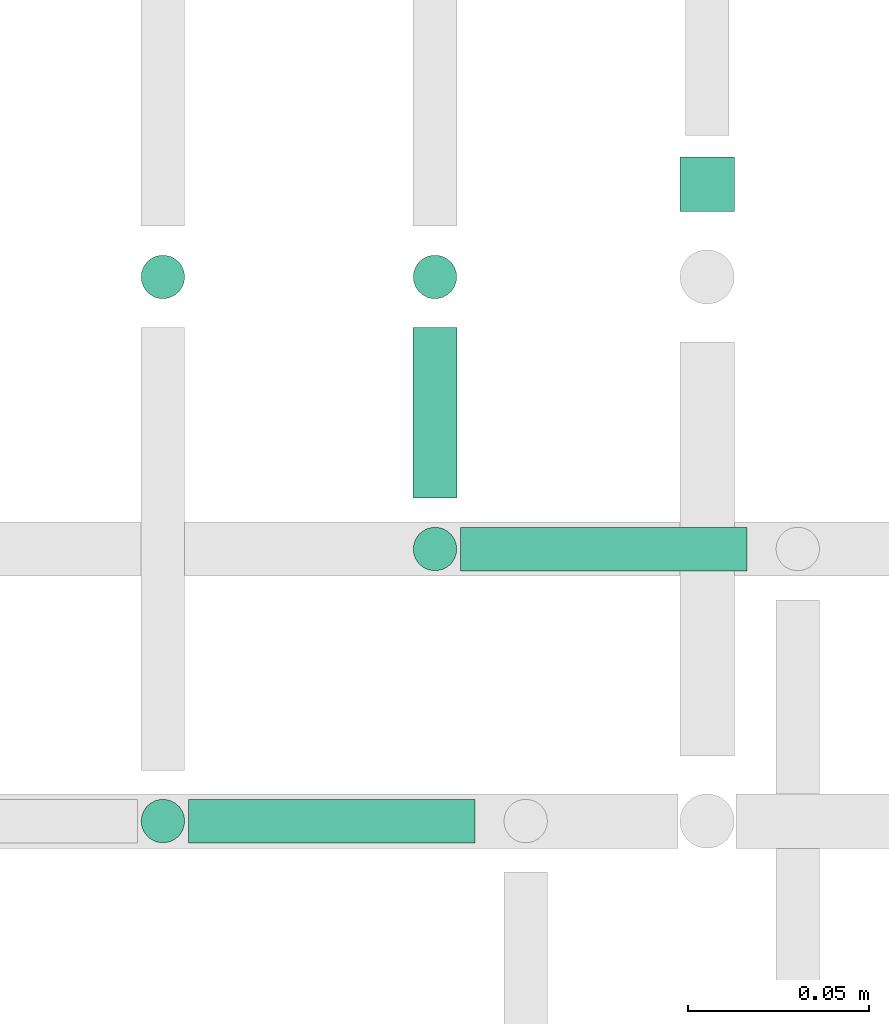
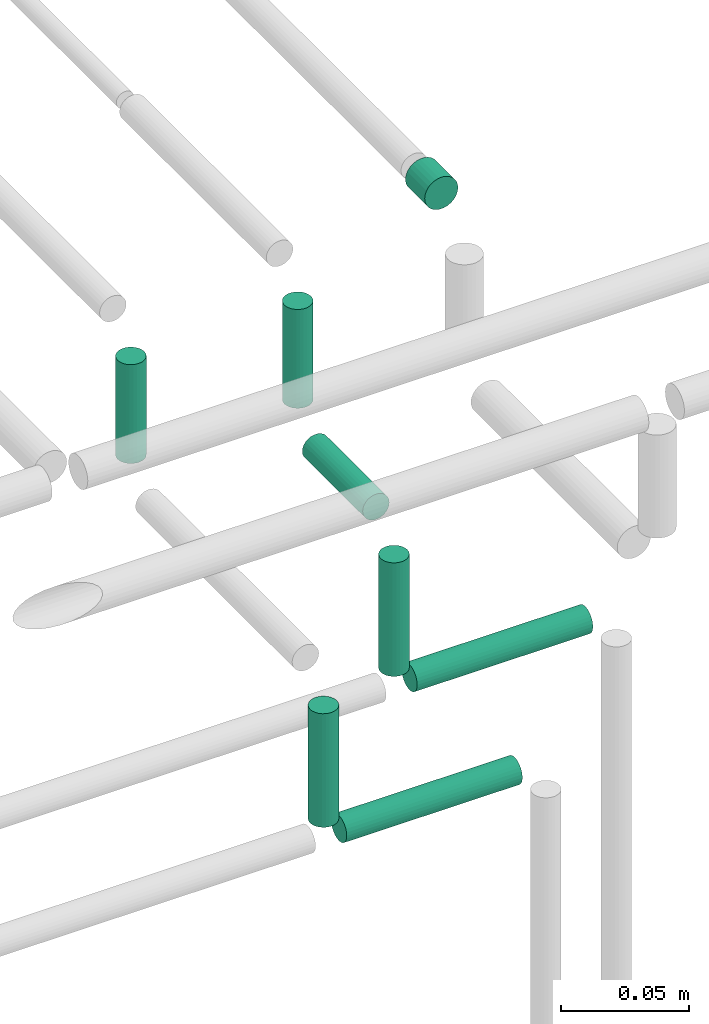
# One storey, part 322 of 331: 8 flow segments.
"""IFC2X3 building model written with IfcOpenShell, lengths in millimetres."""

import ifcopenshell
import ifcopenshell.guid

model = None  # the IFC model being written
_history = None  # IfcOwnerHistory: only IFC2X3 demands one
_inside = {}  # id of a spatial element -> (the spatial element, [elements in it])
_under = {}  # id of a project, library or spatial element -> (it, [spatial elements below it])
_declared = {}  # id of a project -> (the project, [libraries it declares])
_typed = {}  # id of a type object -> (the type object, [elements of that type])
_made_of = {}  # id of a material, layer set ... -> (it, [elements and type objects made of it])


def new_model(schema):
    """Start an empty IFC model of exactly this schema.

    Asked for "IFC4X3", IfcOpenShell would pick the latest addendum, in which some entities
    have other attributes; the version numbers below select the first issue.
    IFC2X3 requires an IfcOwnerHistory on every rooted entity: one is made here for all.
    """
    global model, _history
    if schema == "IFC4X3":
        model = ifcopenshell.file(schema_version=(4, 3, 0, 0))
    else:
        model = ifcopenshell.file(schema=schema)
    _inside.clear()
    _under.clear()
    _declared.clear()
    _typed.clear()
    _made_of.clear()
    _history = None
    if model.schema == "IFC2X3":
        org = make("IfcOrganization", Name="unknown")
        user = make(
            "IfcPersonAndOrganization",
            ThePerson=make("IfcPerson", FamilyName="unknown"),
            TheOrganization=org,
        )
        app = make(
            "IfcApplication",
            ApplicationDeveloper=org,
            Version="unknown",
            ApplicationFullName="unknown",
            ApplicationIdentifier="unknown",
        )
        _history = make(
            "IfcOwnerHistory",
            OwningUser=user,
            OwningApplication=app,
            ChangeAction="ADDED",
            CreationDate=0,
        )
    return model


def make(cls, **values):
    """One entity of the class cls with the attributes given. An attribute that is None is left unset."""
    return model.create_entity(
        cls, **{name: value for name, value in values.items() if value is not None}
    )


def entity(cls, *values):
    """Any entity or typed value of the class cls, its attributes in the order of the schema. None: left unset."""
    e = model.create_entity(cls)
    for i, value in enumerate(values):
        if value is not None:
            e[i] = value
    return e


def rooted(cls, **values):
    """An entity with a GlobalId (a new one), such as an element, a storey or a relation."""
    return make(cls, GlobalId=ifcopenshell.guid.new(), OwnerHistory=_history, **values)


def si_unit(unit_type, name, prefix=None):
    """IfcSIUnit, for example si_unit("LENGTHUNIT", "METRE", prefix="MILLI")."""
    return make("IfcSIUnit", UnitType=unit_type, Prefix=prefix, Name=name)


def converted_unit(unit_type, name, factor, base, dimensions=None, offset=None):
    """IfcConversionBasedUnit, such as the inch: factor (a typed value) times the base unit."""
    return make(
        "IfcConversionBasedUnit"
        if offset is None
        else "IfcConversionBasedUnitWithOffset",
        ConversionOffset=offset,
        Dimensions=None
        if dimensions is None
        else entity("IfcDimensionalExponents", *dimensions),
        UnitType=unit_type,
        Name=name,
        ConversionFactor=make(
            "IfcMeasureWithUnit", ValueComponent=factor, UnitComponent=base
        ),
    )


def derived_unit(unit_type, elements):
    """IfcDerivedUnit: a product of units, each with its exponent."""
    return make(
        "IfcDerivedUnit",
        Elements=[
            make("IfcDerivedUnitElement", Unit=unit, Exponent=power)
            for unit, power in elements
        ],
        UnitType=unit_type,
    )


def assignment(units):
    """IfcUnitAssignment: the units of a project."""
    return None if units is None else make("IfcUnitAssignment", Units=units)


def point(xyz):
    """IfcCartesianPoint."""
    return None if xyz is None else make("IfcCartesianPoint", Coordinates=xyz)


def direction(xyz):
    """IfcDirection."""
    return None if xyz is None else make("IfcDirection", DirectionRatios=xyz)


def frame(location, z_axis=None, x_axis=None):
    """IfcAxis2Placement3D, a coordinate frame: its origin and axes. An axis left out is left unset."""
    return make(
        "IfcAxis2Placement3D",
        Location=point(location),
        Axis=direction(z_axis),
        RefDirection=direction(x_axis),
    )


def frame_2d(location, x_axis=None):
    """IfcAxis2Placement2D, a coordinate frame in the plane: its origin and x axis."""
    return make(
        "IfcAxis2Placement2D", Location=point(location), RefDirection=direction(x_axis)
    )


def origin():
    """The frame at (0, 0, 0) with its axes left unset."""
    return frame((0.0, 0.0, 0.0))


def origin_2d_with_axis():
    """The frame at (0, 0) in the plane with the x axis (1, 0) written out."""
    return frame_2d((0.0, 0.0), x_axis=(1.0, 0.0))


def place(relative_to, where):
    """IfcLocalPlacement: puts the frame where relative to a parent placement (None: the world)."""
    return make(
        "IfcLocalPlacement", PlacementRelTo=relative_to, RelativePlacement=where
    )


def context(
    kind, dimensions, precision=None, world=None, true_north=None, identifier=None
):
    """IfcGeometricRepresentationContext, for example the 3D "Model" context."""
    return make(
        "IfcGeometricRepresentationContext",
        ContextIdentifier=identifier,
        ContextType=kind,
        CoordinateSpaceDimension=dimensions,
        Precision=precision,
        WorldCoordinateSystem=world,
        TrueNorth=true_north,
    )


def subcontext(parent, identifier, kind, view, scale=None):
    """IfcGeometricRepresentationSubContext, for example "Body" below "Model"."""
    return make(
        "IfcGeometricRepresentationSubContext",
        ContextIdentifier=identifier,
        ContextType=kind,
        ParentContext=parent,
        TargetScale=scale,
        TargetView=view,
    )


def project(units=None, contexts=None):
    """IfcProject with its units and contexts."""
    return rooted(
        "IfcProject",
        Name="project",
        RepresentationContexts=contexts,
        UnitsInContext=assignment(units),
    )


def spatial(cls, under=None, at=None, **own):
    """A site, building, storey or space (cls), placed at a placement, below another one or the project."""
    s = rooted(cls, ObjectPlacement=at, **own)
    if under is not None:
        _under.setdefault(under.id(), (under, []))[1].append(s)
    return s


def profile(cls, at=None, kind="AREA", **sizes):
    """A parametric profile (cls). Its sizes go by their IFC names, for example OverallWidth=200.0."""
    return make(cls, ProfileType=kind, Position=at, **sizes)


def circle(**sizes):
    """IfcCircleProfileDef."""
    return profile("IfcCircleProfileDef", **sizes)


def extrude(swept, where, along, depth):
    """IfcExtrudedAreaSolid: the profile swept, set in the frame where, extruded along a direction by depth."""
    return make(
        "IfcExtrudedAreaSolid",
        SweptArea=swept,
        Position=where,
        ExtrudedDirection=direction(along),
        Depth=depth,
    )


def shape(context_of_items, identifier, shape_type, items):
    """IfcShapeRepresentation: the items that make up one representation, for example the "Body"."""
    return make(
        "IfcShapeRepresentation",
        ContextOfItems=context_of_items,
        RepresentationIdentifier=identifier,
        RepresentationType=shape_type,
        Items=items,
    )


def made_of(thing, what):
    """Note that an element or type object is made of a material, layer set ...; save() writes the relation."""
    if what is not None:
        _made_of.setdefault(what.id(), (what, []))[1].append(thing)
    return thing


def type_object(cls, material=None, **own):
    """A type object (cls), such as IfcWallType, which elements share."""
    return made_of(rooted(cls, **own), material)


def element(
    cls,
    number,
    at=None,
    inside=None,
    cuts=None,
    type_object=None,
    material=None,
    context=None,
    identifier="Body",
    shape_type=None,
    held_by="IfcProductDefinitionShape",
    body=None,
    shapes=None,
    **own,
):
    """One element of the class cls, such as IfcWall. Its Tag is "e" and its number.

    at: its placement. inside: the storey or other place that contains it. cuts: it is an
    opening in that element (IfcRelVoidsElement). A single representation is given by context,
    identifier, shape_type and body (its items); several are given by shapes. held_by: the class
    of the entity that holds the representations. save() writes the other relations.
    """
    e = rooted(cls, Tag="e%d" % number, ObjectPlacement=at, **own)
    if body is not None:
        shapes = [shape(context, identifier, shape_type, body)]
    if shapes is not None:
        e.Representation = make(held_by, Representations=shapes)
    if inside is not None:
        _inside.setdefault(inside.id(), (inside, []))[1].append(e)
    if cuts is not None:
        rooted(
            "IfcRelVoidsElement", RelatingBuildingElement=cuts, RelatedOpeningElement=e
        )
    if type_object is not None:
        _typed.setdefault(type_object.id(), (type_object, []))[1].append(e)
    return made_of(e, material)


def aggregate(whole, parts):
    """IfcRelAggregates: a whole, such as a stair, and the parts it consists of."""
    return rooted("IfcRelAggregates", RelatingObject=whole, RelatedObjects=parts)


def save(model, path):
    """Write the relations noted so far, then the file.

    IfcRelAggregates (storeys below a building ...), IfcRelContainedInSpatialStructure (elements
    in a storey), IfcRelDefinesByType, IfcRelAssociatesMaterial and IfcRelDeclares: one each for
    every whole, place, type object, material and project.
    """
    for whole, parts in _under.values():
        aggregate(whole, parts)
    for where, things in _inside.values():
        rooted(
            "IfcRelContainedInSpatialStructure",
            RelatedElements=things,
            RelatingStructure=where,
        )
    for kind, things in _typed.values():
        rooted("IfcRelDefinesByType", RelatedObjects=things, RelatingType=kind)
    for what, things in _made_of.values():
        rooted("IfcRelAssociatesMaterial", RelatedObjects=things, RelatingMaterial=what)
    for by, libraries in _declared.values():
        rooted("IfcRelDeclares", RelatingContext=by, RelatedDefinitions=libraries)
    model.write(path)


model = new_model("IFC2X3")

# Units and contexts
model_context = context("Model", 3, precision=0.01, world=origin(), true_north=direction((6.12303176911189e-17, 1.0)))
body_context = subcontext(model_context, "Body", "Model", "MODEL_VIEW")
ifc_project = project(units=[si_unit("LENGTHUNIT", "METRE", prefix="MILLI"), si_unit("AREAUNIT", "SQUARE_METRE"), si_unit("VOLUMEUNIT", "CUBIC_METRE"), converted_unit("PLANEANGLEUNIT", "DEGREE", entity("IfcRatioMeasure", 0.0174532925199433), si_unit("PLANEANGLEUNIT", "RADIAN"), dimensions=[0, 0, 0, 0, 0, 0, 0]), si_unit("MASSUNIT", "GRAM", prefix="KILO"), derived_unit("MASSDENSITYUNIT", [(si_unit("MASSUNIT", "GRAM", prefix="KILO"), 1), (si_unit("LENGTHUNIT", "METRE"), -3)]), derived_unit("MOMENTOFINERTIAUNIT", [(si_unit("LENGTHUNIT", "METRE"), 4)]), si_unit("TIMEUNIT", "SECOND"), si_unit("FREQUENCYUNIT", "HERTZ"), si_unit("THERMODYNAMICTEMPERATUREUNIT", "DEGREE_CELSIUS"), derived_unit("THERMALTRANSMITTANCEUNIT", [(si_unit("MASSUNIT", "GRAM", prefix="KILO"), 1), (si_unit("THERMODYNAMICTEMPERATUREUNIT", "KELVIN"), -1), (si_unit("TIMEUNIT", "SECOND"), -3)]), derived_unit("VOLUMETRICFLOWRATEUNIT", [(si_unit("LENGTHUNIT", "METRE"), 3), (si_unit("TIMEUNIT", "SECOND"), -1)]), derived_unit("MASSFLOWRATEUNIT", [(si_unit("MASSUNIT", "GRAM", prefix="KILO"), 1), (si_unit("TIMEUNIT", "SECOND"), -1)]), derived_unit("ROTATIONALFREQUENCYUNIT", [(si_unit("TIMEUNIT", "SECOND"), -1)]), si_unit("ELECTRICCURRENTUNIT", "AMPERE"), si_unit("ELECTRICVOLTAGEUNIT", "VOLT"), si_unit("POWERUNIT", "WATT"), si_unit("FORCEUNIT", "NEWTON", prefix="KILO"), si_unit("ILLUMINANCEUNIT", "LUX"), si_unit("LUMINOUSFLUXUNIT", "LUMEN"), si_unit("LUMINOUSINTENSITYUNIT", "CANDELA"), derived_unit("USERDEFINED", [(si_unit("MASSUNIT", "GRAM", prefix="KILO"), -1), (si_unit("LENGTHUNIT", "METRE"), -2), (si_unit("TIMEUNIT", "SECOND"), 3), (si_unit("LUMINOUSFLUXUNIT", "LUMEN"), 1)]), derived_unit("LINEARVELOCITYUNIT", [(si_unit("LENGTHUNIT", "METRE"), 1), (si_unit("TIMEUNIT", "SECOND"), -1)]), si_unit("PRESSUREUNIT", "PASCAL"), derived_unit("USERDEFINED", [(si_unit("LENGTHUNIT", "METRE"), -2), (si_unit("MASSUNIT", "GRAM", prefix="KILO"), 1), (si_unit("TIMEUNIT", "SECOND"), -2)]), derived_unit("LINEARFORCEUNIT", [(si_unit("MASSUNIT", "GRAM", prefix="KILO"), 1), (si_unit("LENGTHUNIT", "METRE"), 1), (si_unit("TIMEUNIT", "SECOND"), -2), (si_unit("LENGTHUNIT", "METRE"), -1)]), derived_unit("PLANARFORCEUNIT", [(si_unit("MASSUNIT", "GRAM", prefix="KILO"), 1), (si_unit("LENGTHUNIT", "METRE"), 1), (si_unit("TIMEUNIT", "SECOND"), -2), (si_unit("LENGTHUNIT", "METRE"), -2)])], contexts=[model_context])

# Site, building, storey
site_placement = place(None, frame((0.0, -0.00077364408347762, 0.0)))
site = spatial("IfcSite", under=ifc_project, at=site_placement, CompositionType="ELEMENT")
building_placement = place(site_placement, origin())
building = spatial("IfcBuilding", under=site, at=building_placement, CompositionType="ELEMENT")
storey_placement = place(building_placement, origin())
storey = spatial("IfcBuildingStorey", under=building, at=storey_placement, CompositionType="ELEMENT", Elevation=0.0)

# Flow segments
pipe_segment_type = type_object("IfcPipeSegmentType", PredefinedType="NOTDEFINED")
flow_segment_1_placement = place(building_placement, frame((61738.5947663298, 16117.5146947319, 18907.0)))
element("IfcFlowSegment", 1, at=flow_segment_1_placement, inside=storey, type_object=pipe_segment_type, context=body_context, shape_type="SweptSolid", body=[
    extrude(circle(Radius=6.0, at=origin_2d_with_axis()), frame((7.59527223591454, 7.5952722359167, 0.0)), (0.0, 0.0, 1.0), 53.9999999999834),
])
flow_segment_2_placement = place(building_placement, frame((61753.1900385657, 16117.5146947319, 18892.4047277641)))
element("IfcFlowSegment", 2, at=flow_segment_2_placement, inside=storey, type_object=pipe_segment_type, context=body_context, shape_type="SweptSolid", body=[
    extrude(circle(Radius=6.0, at=frame_2d((2.16573425859679e-12, -2.16573425859679e-12), x_axis=(1.0, 0.0))), frame((0.0, 7.59527223591887, 7.59527223591887), z_axis=(1.0, 0.0, 0.0), x_axis=(0.0, 1.0, 0.0)), (0.0, 0.0, 1.0), 78.9999999999994),
])
flow_segment_3_placement = place(building_placement, frame((61663.5947663298, 16042.5146947319, 18907.0)))
element("IfcFlowSegment", 3, at=flow_segment_3_placement, inside=storey, type_object=pipe_segment_type, context=body_context, shape_type="SweptSolid", body=[
    extrude(circle(Radius=6.0, at=frame_2d((0.0, -2.16573425859679e-12), x_axis=(1.0, 0.0))), frame((7.59527223591454, 7.59527223591887, 0.0)), (0.0, 0.0, 1.0), 53.9999999999639),
])
flow_segment_4_placement = place(building_placement, frame((61678.1900385657, 16042.5146947319, 18892.4047277641)))
element("IfcFlowSegment", 4, at=flow_segment_4_placement, inside=storey, type_object=pipe_segment_type, context=body_context, shape_type="SweptSolid", body=[
    extrude(circle(Radius=6.0, at=frame_2d((2.16573425859679e-12, 0.0), x_axis=(1.0, 0.0))), frame((0.0, 7.59527223591887, 7.5952722359167), z_axis=(1.0, 0.0, 0.0), x_axis=(0.0, 1.0, 0.0)), (0.0, 0.0, 1.0), 78.9999999999994),
])
flow_segment_5_placement = place(storey_placement, frame((61738.5947663298, 16139.1099669678, 18967.4047277641)))
element("IfcFlowSegment", 5, at=flow_segment_5_placement, inside=storey, type_object=pipe_segment_type, context=body_context, shape_type="SweptSolid", body=[
    extrude(circle(Radius=6.0, at=frame_2d((0.0, -2.16573425859679e-12), x_axis=(1.0, 0.0))), frame((7.59527223591454, 0.0, 7.59527223591887), z_axis=(0.0, 1.0, 0.0), x_axis=(-1.0, 0.0, 0.0)), (0.0, 0.0, 1.0), 47.0000000000175),
])
for number, where in (
    (6, (61738.5947663298, 16192.5146947319, 18989.0)),
    (7, (61663.5947663298, 16192.5146947319, 18989.0)),
):
    element("IfcFlowSegment", number, at=place(storey_placement, frame(where)), inside=storey, type_object=pipe_segment_type, context=body_context, shape_type="SweptSolid", body=[
        extrude(circle(Radius=6.0, at=origin_2d_with_axis()), frame((7.59527223591454, 7.5952722359167, 0.0)), (0.0, 0.0, 1.0), 47.0000000000911),
    ])
flow_segment_6_placement = place(storey_placement, frame((61812.0947663298, 16218.1099669678, 19040.9047277642)))
element("IfcFlowSegment", 8, at=flow_segment_6_placement, inside=storey, type_object=pipe_segment_type, context=body_context, shape_type="SweptSolid", body=[
    extrude(circle(Radius=7.5, at=frame_2d((0.0, -2.16573425859679e-12), x_axis=(1.0, 0.0))), frame((9.09527223591419, 0.0, 9.09527223591419), z_axis=(0.0, 1.0, 0.0), x_axis=(1.0, 0.0, 0.0)), (0.0, 0.0, 1.0), 15.025707153238),
])

save(model, "model.ifc")
